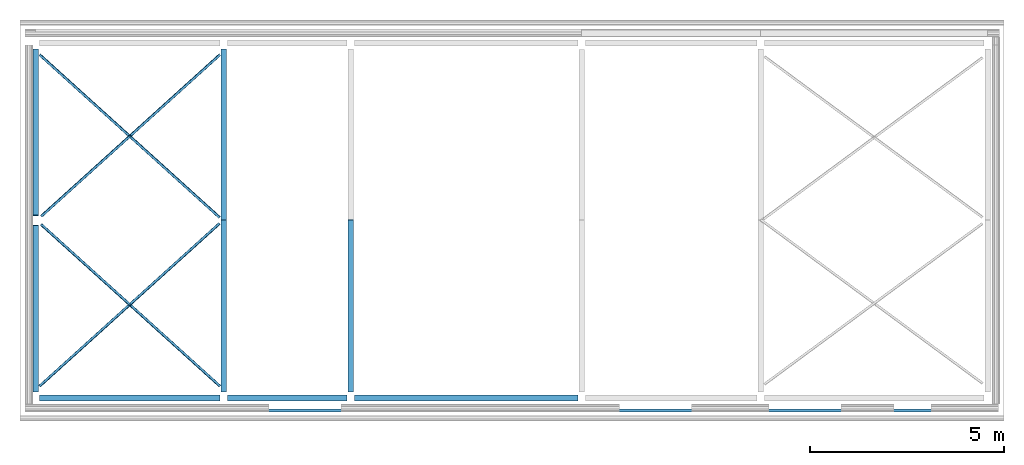
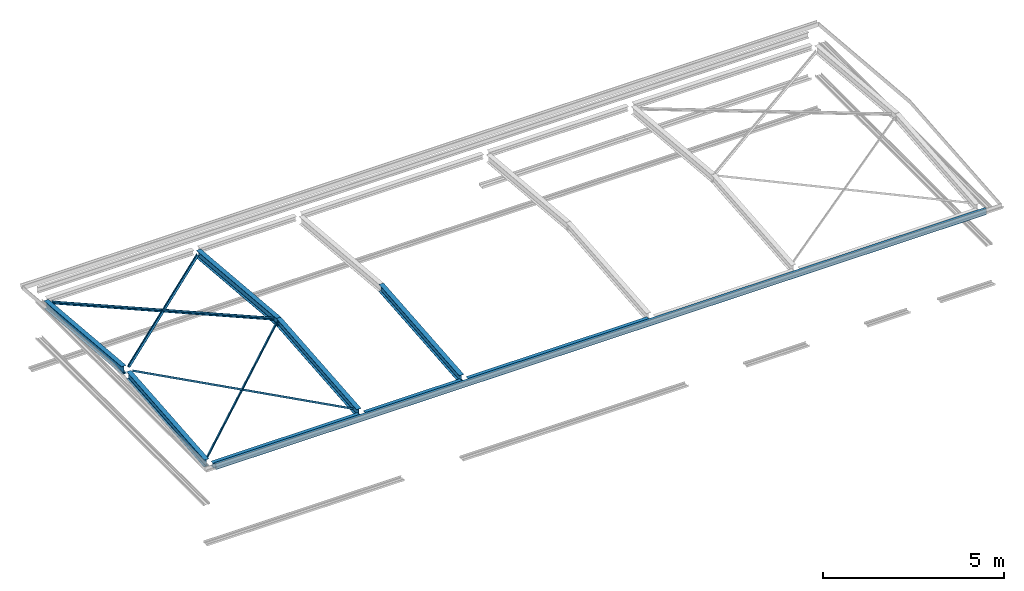
# One storey, part 1 of 8: 13 beams.
"""IFC2X3 building model written with IfcOpenShell, lengths in millimetres."""

from ifc_helpers import new_model, entity, si_unit, converted_unit, money_unit, point, direction, frame, frame_2d, origin_with_axes, place, context, subcontext, project, spatial, polyline, circle_curve, parameter, trimmed, segment, composite_curve, outline, extrude, clip, halfspace, material, type_object, element, save


model = new_model("IFC2X3")

# Units and contexts
model_context = context("Model", 3, precision=1e-05, world=origin_with_axes(), true_north=direction((0.0, 1.0)))
body_context = subcontext(model_context, "Body", "Model", "MODEL_VIEW")
ifc_project = project(units=[si_unit("LENGTHUNIT", "METRE", prefix="MILLI"), si_unit("AREAUNIT", "SQUARE_METRE"), si_unit("VOLUMEUNIT", "CUBIC_METRE"), converted_unit("PLANEANGLEUNIT", "DEGREE", entity("IfcPlaneAngleMeasure", 0.0174532925199), si_unit("PLANEANGLEUNIT", "RADIAN"), dimensions=[0, 0, 0, 0, 0, 0, 0]), si_unit("SOLIDANGLEUNIT", "STERADIAN"), money_unit("USD"), converted_unit("TIMEUNIT", "Year", entity("IfcTimeMeasure", 31556926.0), si_unit("TIMEUNIT", "SECOND"), dimensions=[0, 0, 0, 0, 0, 0, 0]), si_unit("MASSUNIT", "GRAM"), si_unit("THERMODYNAMICTEMPERATUREUNIT", "DEGREE_CELSIUS"), si_unit("LUMINOUSINTENSITYUNIT", "LUMEN")], contexts=[model_context])

# Site, building, storey
site_placement = place(None, origin_with_axes())
site = spatial("IfcSite", under=ifc_project, at=site_placement, CompositionType="ELEMENT")
building_placement = place(site_placement, origin_with_axes())
building = spatial("IfcBuilding", under=site, at=building_placement, CompositionType="ELEMENT")
storey_placement = place(building_placement, frame((0.0, 0.0, 74215.0), z_axis=(0.0, 0.0, 1.0), x_axis=(1.0, 0.0, 0.0)))
storey = spatial("IfcBuildingStorey", under=building, at=storey_placement, CompositionType="ELEMENT", Elevation=74215.0)

# Beams
ifc_material = material(Name="Metal - Steel 43-275")
beam_type_1 = type_object("IfcBeamType", Name="UB254x146x31 (1) 251 x 146", PredefinedType="NOTDEFINED")
beam_1_placement = place(storey_placement, frame((-3274.22088657, 3613.7891505, 267.014681752), z_axis=(0.0, 0.0, 1.0), x_axis=(-1.0, 0.0, 0.0)))
element("IfcBeam", 1, at=beam_1_placement, inside=storey, type_object=beam_type_1, material=ifc_material, Name="UB-Universal Beams:UB254x146x31", ObjectType="UB-Universal Beams:UB254x146x31", context=body_context, shape_type="Clipping", body=[
    clip(clip(clip(clip(extrude(outline(composite_curve([segment(polyline([(125.7, 73.05), (117.1, 73.05), (117.1, 10.6)]), True, "CONTINUOUS"), segment(trimmed(circle_curve(frame_2d((109.5, 10.6), x_axis=(0.0, -1.0)), 7.6), [point((117.1, 10.6)), parameter(90.0)], [point((109.5, 3.0)), parameter(0.0)], False, "CARTESIAN"), True, "CONTINUOUS"), segment(polyline([(109.5, 3.0), (-109.5, 3.0)]), True, "CONTINUOUS"), segment(trimmed(circle_curve(frame_2d((-109.5, 10.6), x_axis=(-1.0, 0.0)), 7.6), [point((-109.5, 3.0)), parameter(90.0)], [point((-117.1, 10.6)), parameter(0.0)], False, "CARTESIAN"), True, "CONTINUOUS"), segment(polyline([(-117.1, 10.6), (-117.1, 73.05), (-125.7, 73.05), (-125.7, -73.05), (-117.1, -73.05), (-117.1, -10.6)]), True, "CONTINUOUS"), segment(trimmed(circle_curve(frame_2d((-109.5, -10.6), x_axis=(0.0, 1.0)), 7.6), [point((-117.1, -10.6)), parameter(90.0)], [point((-109.5, -3.0)), parameter(0.0)], False, "CARTESIAN"), True, "CONTINUOUS"), segment(polyline([(-109.5, -3.0), (109.5, -3.0)]), True, "CONTINUOUS"), segment(trimmed(circle_curve(frame_2d((109.5, -10.6), x_axis=(1.0, 0.0)), 7.6), [point((109.5, -3.0)), parameter(90.0)], [point((117.1, -10.6)), parameter(0.0)], False, "CARTESIAN"), True, "CONTINUOUS"), segment(polyline([(117.1, -10.6), (117.1, -73.05), (125.7, -73.05), (125.7, 73.05)]), True, "CONTINUOUS")], self_intersect=False)), frame((0.0, 4482.93411635, -395.427760455), z_axis=(0.0, -0.996132286365, 0.08786619408), x_axis=(0.0, -0.08786619408, -0.996132286365)), (0.0, 0.0, 1.0), 4518.56524717), halfspace(frame((0.0, 4446.62488753, -392.225019424), z_axis=(0.0, -0.996132286365, 0.08786619408), x_axis=(0.0, -0.08786619408, -0.996132286365)), True)), halfspace(frame((0.0, 18.1546144043, -1.60137051527), z_axis=(0.0, 0.996132286365, -0.08786619408), x_axis=(0.0, 0.08786619408, 0.996132286365)), True)), halfspace(frame((0.0, 4464.77950194, 0.0), z_axis=(0.0, -1.0, 0.0), x_axis=(0.0, 0.0, -1.0)), True)), halfspace(frame((0.0, 0.0, 0.0), z_axis=(0.0, 1.0, 0.0), x_axis=(0.0, 0.0, 1.0)), True)),
])
beam_2_placement = place(storey_placement, frame((-8119.87046131, 3470.08229394, 254.338680059), z_axis=(0.0, 0.0, 1.0), x_axis=(-1.0, 0.0, 0.0)))
element("IfcBeam", 2, at=beam_2_placement, inside=storey, type_object=beam_type_1, material=ifc_material, Name="UB-Universal Beams:UB254x146x31", ObjectType="UB-Universal Beams:UB254x146x31", context=body_context, shape_type="Clipping", body=[
    clip(clip(clip(clip(extrude(outline(composite_curve([segment(polyline([(125.7, 73.05), (117.1, 73.05), (117.1, 10.6)]), True, "CONTINUOUS"), segment(trimmed(circle_curve(frame_2d((109.5, 10.6), x_axis=(0.0, -1.0)), 7.6), [point((117.1, 10.6)), parameter(90.0)], [point((109.5, 3.0)), parameter(0.0)], False, "CARTESIAN"), True, "CONTINUOUS"), segment(polyline([(109.5, 3.0), (-109.5, 3.0)]), True, "CONTINUOUS"), segment(trimmed(circle_curve(frame_2d((-109.5, 10.6), x_axis=(-1.0, 0.0)), 7.6), [point((-109.5, 3.0)), parameter(90.0)], [point((-117.1, 10.6)), parameter(0.0)], False, "CARTESIAN"), True, "CONTINUOUS"), segment(polyline([(-117.1, 10.6), (-117.1, 73.05), (-125.7, 73.05), (-125.7, -73.05), (-117.1, -73.05), (-117.1, -10.6)]), True, "CONTINUOUS"), segment(trimmed(circle_curve(frame_2d((-109.5, -10.6), x_axis=(0.0, 1.0)), 7.6), [point((-117.1, -10.6)), parameter(90.0)], [point((-109.5, -3.0)), parameter(0.0)], False, "CARTESIAN"), True, "CONTINUOUS"), segment(polyline([(-109.5, -3.0), (109.5, -3.0)]), True, "CONTINUOUS"), segment(trimmed(circle_curve(frame_2d((109.5, -10.6), x_axis=(1.0, 0.0)), 7.6), [point((109.5, -3.0)), parameter(90.0)], [point((117.1, -10.6)), parameter(0.0)], False, "CARTESIAN"), True, "CONTINUOUS"), segment(polyline([(117.1, -10.6), (117.1, -73.05), (125.7, -73.05), (125.7, 73.05)]), True, "CONTINUOUS")], self_intersect=False)), frame((0.0, 4339.22725978, -382.751758762), z_axis=(0.0, -0.996132286365, 0.08786619408), x_axis=(0.0, -0.08786619408, -0.996132286365)), (0.0, 0.0, 1.0), 4374.30041555), halfspace(frame((0.0, 4302.91803097, -379.549017731), z_axis=(0.0, -0.996132286365, 0.08786619408), x_axis=(0.0, -0.08786619408, -0.996132286365)), True)), halfspace(frame((0.0, 18.1546144043, -1.60137051527), z_axis=(0.0, 0.996132286365, -0.08786619408), x_axis=(0.0, 0.08786619408, 0.996132286365)), True)), halfspace(frame((0.0, 4321.07264538, 0.0), z_axis=(0.0, -1.0, 0.0), x_axis=(0.0, 0.0, -1.0)), True)), halfspace(frame((0.0, 0.0, 0.0), z_axis=(0.0, 1.0, 0.0), x_axis=(0.0, 0.0, 1.0)), True)),
])
beam_3_placement = place(storey_placement, frame((-8119.87046131, 3684.87754945, 254.338680059), z_axis=(0.0, 0.0, 1.0), x_axis=(1.0, 0.0, 0.0)))
element("IfcBeam", 3, at=beam_3_placement, inside=storey, type_object=beam_type_1, material=ifc_material, Name="UB-Universal Beams:UB254x146x31", ObjectType="UB-Universal Beams:UB254x146x31", context=body_context, shape_type="Clipping", body=[
    clip(clip(clip(clip(extrude(outline(composite_curve([segment(polyline([(125.7, 73.05), (117.1, 73.05), (117.1, 10.6)]), True, "CONTINUOUS"), segment(trimmed(circle_curve(frame_2d((109.5, 10.6), x_axis=(0.0, -1.0)), 7.6), [point((117.1, 10.6)), parameter(90.0)], [point((109.5, 3.0)), parameter(0.0)], False, "CARTESIAN"), True, "CONTINUOUS"), segment(polyline([(109.5, 3.0), (-109.5, 3.0)]), True, "CONTINUOUS"), segment(trimmed(circle_curve(frame_2d((-109.5, 10.6), x_axis=(-1.0, 0.0)), 7.6), [point((-109.5, 3.0)), parameter(90.0)], [point((-117.1, 10.6)), parameter(0.0)], False, "CARTESIAN"), True, "CONTINUOUS"), segment(polyline([(-117.1, 10.6), (-117.1, 73.05), (-125.7, 73.05), (-125.7, -73.05), (-117.1, -73.05), (-117.1, -10.6)]), True, "CONTINUOUS"), segment(trimmed(circle_curve(frame_2d((-109.5, -10.6), x_axis=(0.0, 1.0)), 7.6), [point((-117.1, -10.6)), parameter(90.0)], [point((-109.5, -3.0)), parameter(0.0)], False, "CARTESIAN"), True, "CONTINUOUS"), segment(polyline([(-109.5, -3.0), (109.5, -3.0)]), True, "CONTINUOUS"), segment(trimmed(circle_curve(frame_2d((109.5, -10.6), x_axis=(1.0, 0.0)), 7.6), [point((109.5, -3.0)), parameter(90.0)], [point((117.1, -10.6)), parameter(0.0)], False, "CARTESIAN"), True, "CONTINUOUS"), segment(polyline([(117.1, -10.6), (117.1, -73.05), (125.7, -73.05), (125.7, 73.05)]), True, "CONTINUOUS")], self_intersect=False)), frame((0.0, 4339.22725978, -382.751758762), z_axis=(0.0, -0.996132286365, 0.08786619408), x_axis=(0.0, -0.08786619408, -0.996132286365)), (0.0, 0.0, 1.0), 4374.30041555), halfspace(frame((0.0, 4302.91803097, -379.549017731), z_axis=(0.0, -0.996132286365, 0.08786619408), x_axis=(0.0, -0.08786619408, -0.996132286365)), True)), halfspace(frame((0.0, 18.1546144043, -1.60137051527), z_axis=(0.0, 0.996132286365, -0.08786619408), x_axis=(0.0, 0.08786619408, 0.996132286365)), True)), halfspace(frame((0.0, 4321.07264538, 0.0), z_axis=(0.0, -1.0, 0.0), x_axis=(0.0, 0.0, -1.0)), True)), halfspace(frame((0.0, 0.0, 0.0), z_axis=(0.0, 1.0, 0.0), x_axis=(0.0, 0.0, 1.0)), True)),
])
beam_4_placement = place(storey_placement, frame((-3274.22088657, 3541.17069288, 267.014681752), z_axis=(0.0, 0.0, 1.0), x_axis=(1.0, 0.0, 0.0)))
element("IfcBeam", 4, at=beam_4_placement, inside=storey, type_object=beam_type_1, material=ifc_material, Name="UB-Universal Beams:UB254x146x31", ObjectType="UB-Universal Beams:UB254x146x31", context=body_context, shape_type="Clipping", body=[
    clip(clip(clip(clip(extrude(outline(composite_curve([segment(polyline([(125.7, 73.05), (117.1, 73.05), (117.1, 10.6)]), True, "CONTINUOUS"), segment(trimmed(circle_curve(frame_2d((109.5, 10.6), x_axis=(0.0, -1.0)), 7.6), [point((117.1, 10.6)), parameter(90.0)], [point((109.5, 3.0)), parameter(0.0)], False, "CARTESIAN"), True, "CONTINUOUS"), segment(polyline([(109.5, 3.0), (-109.5, 3.0)]), True, "CONTINUOUS"), segment(trimmed(circle_curve(frame_2d((-109.5, 10.6), x_axis=(-1.0, 0.0)), 7.6), [point((-109.5, 3.0)), parameter(90.0)], [point((-117.1, 10.6)), parameter(0.0)], False, "CARTESIAN"), True, "CONTINUOUS"), segment(polyline([(-117.1, 10.6), (-117.1, 73.05), (-125.7, 73.05), (-125.7, -73.05), (-117.1, -73.05), (-117.1, -10.6)]), True, "CONTINUOUS"), segment(trimmed(circle_curve(frame_2d((-109.5, -10.6), x_axis=(0.0, 1.0)), 7.6), [point((-117.1, -10.6)), parameter(90.0)], [point((-109.5, -3.0)), parameter(0.0)], False, "CARTESIAN"), True, "CONTINUOUS"), segment(polyline([(-109.5, -3.0), (109.5, -3.0)]), True, "CONTINUOUS"), segment(trimmed(circle_curve(frame_2d((109.5, -10.6), x_axis=(1.0, 0.0)), 7.6), [point((109.5, -3.0)), parameter(90.0)], [point((117.1, -10.6)), parameter(0.0)], False, "CARTESIAN"), True, "CONTINUOUS"), segment(polyline([(117.1, -10.6), (117.1, -73.05), (125.7, -73.05), (125.7, 73.05)]), True, "CONTINUOUS")], self_intersect=False)), frame((0.0, 4482.93411635, -395.427760455), z_axis=(0.0, -0.996132286365, 0.08786619408), x_axis=(0.0, -0.08786619408, -0.996132286365)), (0.0, 0.0, 1.0), 4518.56524717), halfspace(frame((0.0, 4446.62488753, -392.225019424), z_axis=(0.0, -0.996132286365, 0.08786619408), x_axis=(0.0, -0.08786619408, -0.996132286365)), True)), halfspace(frame((0.0, 18.1546144043, -1.60137051527), z_axis=(0.0, 0.996132286365, -0.08786619408), x_axis=(0.0, 0.08786619408, 0.996132286365)), True)), halfspace(frame((0.0, 4464.77950194, 0.0), z_axis=(0.0, -1.0, 0.0), x_axis=(0.0, 0.0, -1.0)), True)), halfspace(frame((0.0, 0.0, 0.0), z_axis=(0.0, 1.0, 0.0), x_axis=(0.0, 0.0, 1.0)), True)),
])
beam_5_placement = place(storey_placement, frame((-6.72084898817, 3613.7891505, 267.014681752), z_axis=(0.0, 0.0, 1.0), x_axis=(-1.0, 0.0, 0.0)))
element("IfcBeam", 5, at=beam_5_placement, inside=storey, type_object=beam_type_1, material=ifc_material, Name="UB-Universal Beams:UB254x146x31", ObjectType="UB-Universal Beams:UB254x146x31", context=body_context, shape_type="Clipping", body=[
    clip(clip(clip(clip(extrude(outline(composite_curve([segment(polyline([(125.7, 73.05), (117.1, 73.05), (117.1, 10.6)]), True, "CONTINUOUS"), segment(trimmed(circle_curve(frame_2d((109.5, 10.6), x_axis=(0.0, -1.0)), 7.6), [point((117.1, 10.6)), parameter(90.0)], [point((109.5, 3.0)), parameter(0.0)], False, "CARTESIAN"), True, "CONTINUOUS"), segment(polyline([(109.5, 3.0), (-109.5, 3.0)]), True, "CONTINUOUS"), segment(trimmed(circle_curve(frame_2d((-109.5, 10.6), x_axis=(-1.0, 0.0)), 7.6), [point((-109.5, 3.0)), parameter(90.0)], [point((-117.1, 10.6)), parameter(0.0)], False, "CARTESIAN"), True, "CONTINUOUS"), segment(polyline([(-117.1, 10.6), (-117.1, 73.05), (-125.7, 73.05), (-125.7, -73.05), (-117.1, -73.05), (-117.1, -10.6)]), True, "CONTINUOUS"), segment(trimmed(circle_curve(frame_2d((-109.5, -10.6), x_axis=(0.0, 1.0)), 7.6), [point((-117.1, -10.6)), parameter(90.0)], [point((-109.5, -3.0)), parameter(0.0)], False, "CARTESIAN"), True, "CONTINUOUS"), segment(polyline([(-109.5, -3.0), (109.5, -3.0)]), True, "CONTINUOUS"), segment(trimmed(circle_curve(frame_2d((109.5, -10.6), x_axis=(1.0, 0.0)), 7.6), [point((109.5, -3.0)), parameter(90.0)], [point((117.1, -10.6)), parameter(0.0)], False, "CARTESIAN"), True, "CONTINUOUS"), segment(polyline([(117.1, -10.6), (117.1, -73.05), (125.7, -73.05), (125.7, 73.05)]), True, "CONTINUOUS")], self_intersect=False)), frame((0.0, 4482.93411635, -395.427760455), z_axis=(0.0, -0.996132286365, 0.08786619408), x_axis=(0.0, -0.08786619408, -0.996132286365)), (0.0, 0.0, 1.0), 4518.56524717), halfspace(frame((0.0, 4446.62488753, -392.225019424), z_axis=(0.0, -0.996132286365, 0.08786619408), x_axis=(0.0, -0.08786619408, -0.996132286365)), True)), halfspace(frame((0.0, 18.1546144043, -1.60137051527), z_axis=(0.0, 0.996132286365, -0.08786619408), x_axis=(0.0, 0.08786619408, 0.996132286365)), True)), halfspace(frame((0.0, 4464.77950194, 0.0), z_axis=(0.0, -1.0, 0.0), x_axis=(0.0, 0.0, -1.0)), True)), halfspace(frame((0.0, 0.0, 0.0), z_axis=(0.0, 1.0, 0.0), x_axis=(0.0, 0.0, 1.0)), True)),
])
beam_type_2 = type_object("IfcBeamType", Name="UC152x152x23 152 x 152", PredefinedType="NOTDEFINED")
beam_6_placement = place(storey_placement, frame((-3369.44567394, -995.620091701, -116.2), z_axis=(0.0, 0.0, 1.0), x_axis=(0.0, 1.0, 0.0)))
element("IfcBeam", 6, at=beam_6_placement, inside=storey, type_object=beam_type_2, material=ifc_material, Name="UC-Universal Columns:UC152x152x23", ObjectType="UC-Universal Columns:UC152x152x23", context=body_context, shape_type="SweptSolid", body=[
    extrude(outline(composite_curve([segment(polyline([(76.2, 76.1), (69.4, 76.1), (69.4, 10.4999999999)]), True, "CONTINUOUS"), segment(trimmed(circle_curve(frame_2d((61.8, 10.4999999999), x_axis=(0.0, -1.0)), 7.60000000002), [point((69.4, 10.4999999999)), parameter(90.0)], [point((61.8, 2.89999999987)), parameter(0.0)], False, "CARTESIAN"), True, "CONTINUOUS"), segment(polyline([(61.8, 2.89999999987), (-61.8, 2.89999999987)]), True, "CONTINUOUS"), segment(trimmed(circle_curve(frame_2d((-61.8, 10.4999999999), x_axis=(-1.0, 0.0)), 7.60000000002), [point((-61.8, 2.89999999987)), parameter(90.0)], [point((-69.4, 10.4999999999)), parameter(0.0)], False, "CARTESIAN"), True, "CONTINUOUS"), segment(polyline([(-69.4, 10.4999999999), (-69.4, 76.1), (-76.2, 76.1), (-76.2, -76.1), (-69.4, -76.1), (-69.4, -10.4999999999)]), True, "CONTINUOUS"), segment(trimmed(circle_curve(frame_2d((-61.8, -10.4999999999), x_axis=(0.0, 1.0)), 7.60000000002), [point((-69.4, -10.4999999999)), parameter(90.0)], [point((-61.8, -2.89999999987)), parameter(0.0)], False, "CARTESIAN"), True, "CONTINUOUS"), segment(polyline([(-61.8, -2.89999999987), (61.8, -2.89999999987)]), True, "CONTINUOUS"), segment(trimmed(circle_curve(frame_2d((61.8, -10.4999999999), x_axis=(1.0, 0.0)), 7.60000000002), [point((61.8, -2.89999999987)), parameter(90.0)], [point((69.4, -10.4999999999)), parameter(0.0)], False, "CARTESIAN"), True, "CONTINUOUS"), segment(polyline([(69.4, -10.4999999999), (69.4, -76.1), (76.2, -76.1), (76.2, 76.1)]), True, "CONTINUOUS")], self_intersect=False)), frame((0.0, 4655.2, 0.0), z_axis=(0.0, -1.0, 0.0), x_axis=(0.0, 0.0, -1.0)), (0.0, 0.0, 1.0), 4655.2),
])
beam_7_placement = place(storey_placement, frame((-101.92086778, -995.620091701, -116.2), z_axis=(0.0, 0.0, 1.0), x_axis=(0.0, 1.0, 0.0)))
element("IfcBeam", 7, at=beam_7_placement, inside=storey, type_object=beam_type_2, material=ifc_material, Name="UC-Universal Columns:UC152x152x23", ObjectType="UC-Universal Columns:UC152x152x23", context=body_context, shape_type="SweptSolid", body=[
    extrude(outline(composite_curve([segment(polyline([(76.2, 76.1), (69.4, 76.1), (69.4, 10.4999999999)]), True, "CONTINUOUS"), segment(trimmed(circle_curve(frame_2d((61.8, 10.4999999999), x_axis=(0.0, -1.0)), 7.60000000002), [point((69.4, 10.4999999999)), parameter(90.0)], [point((61.8, 2.89999999987)), parameter(0.0)], False, "CARTESIAN"), True, "CONTINUOUS"), segment(polyline([(61.8, 2.89999999987), (-61.8, 2.89999999987)]), True, "CONTINUOUS"), segment(trimmed(circle_curve(frame_2d((-61.8, 10.4999999999), x_axis=(-1.0, 0.0)), 7.60000000002), [point((-61.8, 2.89999999987)), parameter(90.0)], [point((-69.4, 10.4999999999)), parameter(0.0)], False, "CARTESIAN"), True, "CONTINUOUS"), segment(polyline([(-69.4, 10.4999999999), (-69.4, 76.1), (-76.2, 76.1), (-76.2, -76.1), (-69.4, -76.1), (-69.4, -10.4999999999)]), True, "CONTINUOUS"), segment(trimmed(circle_curve(frame_2d((-61.8, -10.4999999999), x_axis=(0.0, 1.0)), 7.60000000002), [point((-69.4, -10.4999999999)), parameter(90.0)], [point((-61.8, -2.89999999987)), parameter(0.0)], False, "CARTESIAN"), True, "CONTINUOUS"), segment(polyline([(-61.8, -2.89999999987), (61.8, -2.89999999987)]), True, "CONTINUOUS"), segment(trimmed(circle_curve(frame_2d((61.8, -10.4999999999), x_axis=(1.0, 0.0)), 7.60000000002), [point((61.8, -2.89999999987)), parameter(90.0)], [point((69.4, -10.4999999999)), parameter(0.0)], False, "CARTESIAN"), True, "CONTINUOUS"), segment(polyline([(69.4, -10.4999999999), (69.4, -76.1), (76.2, -76.1), (76.2, 76.1)]), True, "CONTINUOUS")], self_intersect=False)), frame((0.0, 3077.1, 0.0), z_axis=(0.0, -1.0, 0.0), x_axis=(0.0, 0.0, -1.0)), (0.0, 0.0, 1.0), 3077.1),
])
beam_8_placement = place(storey_placement, frame((5850.9874698, -995.620091702, -116.2), z_axis=(0.0, 0.0, 1.0), x_axis=(0.0, 1.0, 0.0)))
element("IfcBeam", 8, at=beam_8_placement, inside=storey, type_object=beam_type_2, material=ifc_material, Name="UC-Universal Columns:UC152x152x23", ObjectType="UC-Universal Columns:UC152x152x23", context=body_context, shape_type="SweptSolid", body=[
    extrude(outline(composite_curve([segment(polyline([(76.2, 76.1), (69.4, 76.1), (69.4, 10.4999999999)]), True, "CONTINUOUS"), segment(trimmed(circle_curve(frame_2d((61.8, 10.4999999999), x_axis=(0.0, -1.0)), 7.60000000002), [point((69.4, 10.4999999999)), parameter(90.0)], [point((61.8, 2.89999999987)), parameter(0.0)], False, "CARTESIAN"), True, "CONTINUOUS"), segment(polyline([(61.8, 2.89999999987), (-61.8, 2.89999999987)]), True, "CONTINUOUS"), segment(trimmed(circle_curve(frame_2d((-61.8, 10.4999999999), x_axis=(-1.0, 0.0)), 7.60000000002), [point((-61.8, 2.89999999987)), parameter(90.0)], [point((-69.4, 10.4999999999)), parameter(0.0)], False, "CARTESIAN"), True, "CONTINUOUS"), segment(polyline([(-69.4, 10.4999999999), (-69.4, 76.1), (-76.2, 76.1), (-76.2, -76.1), (-69.4, -76.1), (-69.4, -10.4999999999)]), True, "CONTINUOUS"), segment(trimmed(circle_curve(frame_2d((-61.8, -10.4999999999), x_axis=(0.0, 1.0)), 7.60000000002), [point((-69.4, -10.4999999999)), parameter(90.0)], [point((-61.8, -2.89999999987)), parameter(0.0)], False, "CARTESIAN"), True, "CONTINUOUS"), segment(polyline([(-61.8, -2.89999999987), (61.8, -2.89999999987)]), True, "CONTINUOUS"), segment(trimmed(circle_curve(frame_2d((61.8, -10.4999999999), x_axis=(1.0, 0.0)), 7.60000000002), [point((61.8, -2.89999999987)), parameter(90.0)], [point((69.4, -10.4999999999)), parameter(0.0)], False, "CARTESIAN"), True, "CONTINUOUS"), segment(polyline([(69.4, -10.4999999999), (69.4, -76.1), (76.2, -76.1), (76.2, 76.1)]), True, "CONTINUOUS")], self_intersect=False)), frame((0.0, 5762.5, 0.0), z_axis=(0.0, -1.0, 0.0), x_axis=(0.0, 0.0, -1.0)), (0.0, 0.0, 1.0), 5762.5),
])
beam_type_3 = type_object("IfcBeamType", Name="L70x70x7 70 x 70", PredefinedType="NOTDEFINED")
beam_9_placement = place(storey_placement, frame((-7992.07752569, 3471.00567283, 336.535227844), z_axis=(0.0, 0.0, 1.0), x_axis=(-0.67073896884, -0.741693491734, 0.0)))
element("IfcBeam", 9, at=beam_9_placement, inside=storey, type_object=beam_type_3, material=ifc_material, Name="L-Equal Leg Angles:L70x70x7", ObjectType="L-Equal Leg Angles:L70x70x7", context=body_context, shape_type="Clipping", body=[
    clip(clip(clip(clip(extrude(outline(composite_curve([segment(polyline([(23.9444444444, -43.5555555556), (26.4444444444, -43.5555555556), (26.4444444444, 26.4444444444), (-43.5555555556, 26.4444444445), (-43.5555555556, 23.9444444445)]), True, "CONTINUOUS"), segment(trimmed(circle_curve(frame_2d((-39.0555555556, 23.9444444445), x_axis=(-1.0, 0.0)), 4.5), [point((-43.5555555556, 23.9444444445)), parameter(0.0)], [point((-39.0555555555, 19.4444444445)), parameter(90.0000000013)], True, "CARTESIAN"), True, "CONTINUOUS"), segment(polyline([(-39.0555555555, 19.4444444445), (10.4444444444, 19.4444444444)]), True, "CONTINUOUS"), segment(trimmed(circle_curve(frame_2d((10.4444444444, 10.4444444444), x_axis=(1.0, 0.0)), 9.0), [point((10.4444444444, 19.4444444444)), parameter(90.0)], [point((19.4444444444, 10.4444444444)), parameter(0.0)], False, "CARTESIAN"), True, "CONTINUOUS"), segment(polyline([(19.4444444444, 10.4444444444), (19.4444444444, -39.0555555556)]), True, "CONTINUOUS"), segment(trimmed(circle_curve(frame_2d((23.9444444444, -39.0555555556), x_axis=(-1.0, 0.0)), 4.5), [point((19.4444444444, -39.0555555556)), parameter(0.0)], [point((23.9444444444, -43.5555555556)), parameter(90.0)], True, "CARTESIAN"), True, "CONTINUOUS")], self_intersect=False)), frame((0.0, 6232.07302353, -368.715055444), z_axis=(0.0, -0.998254385446, 0.0590608325171), x_axis=(0.0, -0.0590608325171, -0.998254385446)), (0.0, 0.0, 1.0), 6248.8277924), halfspace(frame((0.0, 6220.37957528, -368.023222983), z_axis=(0.0, -0.998254385446, 0.0590608325171), x_axis=(0.0, -0.0590608325171, -0.998254385446)), True)), halfspace(frame((0.0, 5.84672412455, -0.345916230701), z_axis=(0.0, 0.998254385446, -0.0590608325171), x_axis=(0.0, 0.0590608325171, 0.998254385446)), True)), halfspace(frame((0.0, 6226.22629941, 0.0), z_axis=(0.0, -1.0, 0.0), x_axis=(0.0, 0.0, -1.0)), True)), halfspace(frame((0.0, 0.0, 0.0), z_axis=(0.0, 1.0, 0.0), x_axis=(0.0, 0.0, 1.0)), True)),
])
beam_10_placement = place(storey_placement, frame((-3371.25025285, 3656.13361529, 338.989205435), z_axis=(0.0, 0.0, 1.0), x_axis=(0.67073896884, 0.741693491734, 0.0)))
element("IfcBeam", 10, at=beam_10_placement, inside=storey, type_object=beam_type_3, material=ifc_material, Name="L-Equal Leg Angles:L70x70x7", ObjectType="L-Equal Leg Angles:L70x70x7", context=body_context, shape_type="Clipping", body=[
    clip(clip(clip(clip(extrude(outline(composite_curve([segment(polyline([(23.9444444444, -43.5555555556), (26.4444444444, -43.5555555556), (26.4444444444, 26.4444444444), (-43.5555555556, 26.4444444445), (-43.5555555556, 23.9444444445)]), True, "CONTINUOUS"), segment(trimmed(circle_curve(frame_2d((-39.0555555556, 23.9444444445), x_axis=(-1.0, 0.0)), 4.5), [point((-43.5555555556, 23.9444444445)), parameter(0.0)], [point((-39.0555555555, 19.4444444445)), parameter(90.0000000013)], True, "CARTESIAN"), True, "CONTINUOUS"), segment(polyline([(-39.0555555555, 19.4444444445), (10.4444444444, 19.4444444444)]), True, "CONTINUOUS"), segment(trimmed(circle_curve(frame_2d((10.4444444444, 10.4444444444), x_axis=(1.0, 0.0)), 9.0), [point((10.4444444444, 19.4444444444)), parameter(90.0)], [point((19.4444444444, 10.4444444444)), parameter(0.0)], False, "CARTESIAN"), True, "CONTINUOUS"), segment(polyline([(19.4444444444, 10.4444444444), (19.4444444444, -39.0555555556)]), True, "CONTINUOUS"), segment(trimmed(circle_curve(frame_2d((23.9444444444, -39.0555555556), x_axis=(-1.0, 0.0)), 4.5), [point((19.4444444444, -39.0555555556)), parameter(0.0)], [point((23.9444444444, -43.5555555556)), parameter(90.0)], True, "CARTESIAN"), True, "CONTINUOUS")], self_intersect=False)), frame((0.0, 6273.60040596, -371.171986077), z_axis=(0.0, -0.998254385446, 0.0590608325171), x_axis=(0.0, -0.0590608325171, -0.998254385446)), (0.0, 0.0, 1.0), 6290.42779239), halfspace(frame((0.0, 6261.90695772, -370.480153616), z_axis=(0.0, -0.998254385446, 0.0590608325171), x_axis=(0.0, -0.0590608325171, -0.998254385446)), True)), halfspace(frame((0.0, 5.84672412452, -0.345916230699), z_axis=(0.0, 0.998254385446, -0.0590608325171), x_axis=(0.0, 0.0590608325171, 0.998254385446)), True)), halfspace(frame((0.0, 6267.75368184, 0.0), z_axis=(0.0, -1.0, 0.0), x_axis=(0.0, 0.0, -1.0)), True)), halfspace(frame((0.0, 0.0, 0.0), z_axis=(0.0, 1.0, 0.0), x_axis=(0.0, 0.0, 1.0)), True)),
])
beam_type_4 = type_object("IfcBeamType", Name="L70x70x7 (1) 70 x 70", PredefinedType="NOTDEFINED")
beam_11_placement = place(storey_placement, frame((-3371.25025285, 3498.8262281, 338.989205435), z_axis=(0.0, 0.0, 1.0), x_axis=(-0.67073896884, 0.741693491734, 0.0)))
element("IfcBeam", 11, at=beam_11_placement, inside=storey, type_object=beam_type_4, material=ifc_material, Name="L-Equal Leg Angles:L70x70x7", ObjectType="L-Equal Leg Angles:L70x70x7", context=body_context, shape_type="Clipping", body=[
    clip(clip(clip(clip(extrude(outline(composite_curve([segment(polyline([(-43.5555555556, -26.4444444444), (26.4444444444, -26.4444444444), (26.4444444444, 43.5555555556), (23.9444444444, 43.5555555556)]), True, "CONTINUOUS"), segment(trimmed(circle_curve(frame_2d((23.9444444444, 39.0555555556), x_axis=(0.0, 1.0)), 4.5), [point((23.9444444444, 43.5555555556)), parameter(0.0)], [point((19.4444444444, 39.0555555555)), parameter(90.0000000013)], True, "CARTESIAN"), True, "CONTINUOUS"), segment(polyline([(19.4444444444, 39.0555555555), (19.4444444444, -10.4444444444)]), True, "CONTINUOUS"), segment(trimmed(circle_curve(frame_2d((10.4444444444, -10.4444444444), x_axis=(0.0, -1.0)), 9.0), [point((19.4444444444, -10.4444444444)), parameter(90.0)], [point((10.4444444444, -19.4444444444)), parameter(0.0)], False, "CARTESIAN"), True, "CONTINUOUS"), segment(polyline([(10.4444444444, -19.4444444444), (-39.0555555556, -19.4444444444)]), True, "CONTINUOUS"), segment(trimmed(circle_curve(frame_2d((-39.0555555556, -23.9444444443), x_axis=(0.0, 1.0)), 4.49999999995), [point((-39.0555555556, -19.4444444444)), parameter(0.0)], [point((-43.5555555555, -23.9444444445)), parameter(90.0000000013)], True, "CARTESIAN"), True, "CONTINUOUS"), segment(polyline([(-43.5555555555, -23.9444444445), (-43.5555555556, -26.4444444444)]), True, "CONTINUOUS")], self_intersect=False)), frame((0.0, 6273.60040596, -371.171986077), z_axis=(0.0, -0.998254385446, 0.0590608325171), x_axis=(0.0, -0.0590608325171, -0.998254385446)), (0.0, 0.0, 1.0), 6290.42779239), halfspace(frame((0.0, 6261.90695772, -370.480153616), z_axis=(0.0, -0.998254385446, 0.0590608325171), x_axis=(0.0, -0.0590608325171, -0.998254385446)), True)), halfspace(frame((0.0, 5.84672412452, -0.345916230699), z_axis=(0.0, 0.998254385446, -0.0590608325171), x_axis=(0.0, 0.0590608325171, 0.998254385446)), True)), halfspace(frame((0.0, 6267.75368184, 0.0), z_axis=(0.0, -1.0, 0.0), x_axis=(0.0, 0.0, -1.0)), True)), halfspace(frame((0.0, 0.0, 0.0), z_axis=(0.0, 1.0, 0.0), x_axis=(0.0, 0.0, 1.0)), True)),
])
beam_12_placement = place(storey_placement, frame((-7992.07752569, 3683.95417056, 336.535227844), z_axis=(0.0, 0.0, 1.0), x_axis=(0.67073896884, -0.741693491734, 0.0)))
element("IfcBeam", 12, at=beam_12_placement, inside=storey, type_object=beam_type_4, material=ifc_material, Name="L-Equal Leg Angles:L70x70x7", ObjectType="L-Equal Leg Angles:L70x70x7", context=body_context, shape_type="Clipping", body=[
    clip(clip(clip(clip(extrude(outline(composite_curve([segment(polyline([(-43.5555555556, -26.4444444444), (26.4444444444, -26.4444444444), (26.4444444444, 43.5555555556), (23.9444444444, 43.5555555556)]), True, "CONTINUOUS"), segment(trimmed(circle_curve(frame_2d((23.9444444444, 39.0555555556), x_axis=(0.0, 1.0)), 4.5), [point((23.9444444444, 43.5555555556)), parameter(0.0)], [point((19.4444444444, 39.0555555555)), parameter(90.0000000013)], True, "CARTESIAN"), True, "CONTINUOUS"), segment(polyline([(19.4444444444, 39.0555555555), (19.4444444444, -10.4444444444)]), True, "CONTINUOUS"), segment(trimmed(circle_curve(frame_2d((10.4444444444, -10.4444444444), x_axis=(0.0, -1.0)), 9.0), [point((19.4444444444, -10.4444444444)), parameter(90.0)], [point((10.4444444444, -19.4444444444)), parameter(0.0)], False, "CARTESIAN"), True, "CONTINUOUS"), segment(polyline([(10.4444444444, -19.4444444444), (-39.0555555556, -19.4444444444)]), True, "CONTINUOUS"), segment(trimmed(circle_curve(frame_2d((-39.0555555556, -23.9444444443), x_axis=(0.0, 1.0)), 4.49999999995), [point((-39.0555555556, -19.4444444444)), parameter(0.0)], [point((-43.5555555555, -23.9444444445)), parameter(90.0000000013)], True, "CARTESIAN"), True, "CONTINUOUS"), segment(polyline([(-43.5555555555, -23.9444444445), (-43.5555555556, -26.4444444444)]), True, "CONTINUOUS")], self_intersect=False)), frame((0.0, 6232.07302353, -368.715055444), z_axis=(0.0, -0.998254385446, 0.0590608325171), x_axis=(0.0, -0.0590608325171, -0.998254385446)), (0.0, 0.0, 1.0), 6248.8277924), halfspace(frame((0.0, 6220.37957528, -368.023222983), z_axis=(0.0, -0.998254385446, 0.0590608325171), x_axis=(0.0, -0.0590608325171, -0.998254385446)), True)), halfspace(frame((0.0, 5.84672412456, -0.345916230701), z_axis=(0.0, 0.998254385446, -0.0590608325171), x_axis=(0.0, 0.0590608325171, 0.998254385446)), True)), halfspace(frame((0.0, 6226.22629941, 0.0), z_axis=(0.0, -1.0, 0.0), x_axis=(0.0, 0.0, -1.0)), True)), halfspace(frame((0.0, 0.0, 0.0), z_axis=(0.0, 1.0, 0.0), x_axis=(0.0, 0.0, 1.0)), True)),
])
beam_type_5 = type_object("IfcBeamType", Name="PFC200x75x23 200 x 75", PredefinedType="NOTDEFINED")
beam_13_placement = place(storey_placement, frame((16408.2545075, -1317.52006319, 60.0), z_axis=(0.0, 0.0, 1.0), x_axis=(0.0, 1.0, 0.0)))
element("IfcBeam", 13, at=beam_13_placement, inside=storey, type_object=beam_type_5, material=ifc_material, Name="PFC-Parallel Flange Channels:PFC200x75x23", ObjectType="PFC-Parallel Flange Channels:PFC200x75x23", context=body_context, shape_type="SweptSolid", body=[
    extrude(outline(composite_curve([segment(polyline([(-100.0, -34.8), (100.0, -34.8), (100.0, 40.2), (87.5, 40.2), (87.5, -16.8)]), True, "CONTINUOUS"), segment(trimmed(circle_curve(frame_2d((75.5, -16.8), x_axis=(0.0, -1.0)), 12.0), [point((87.5, -16.8)), parameter(90.0)], [point((75.5, -28.8)), parameter(0.0)], False, "CARTESIAN"), True, "CONTINUOUS"), segment(polyline([(75.5, -28.8), (-75.5, -28.8)]), True, "CONTINUOUS"), segment(trimmed(circle_curve(frame_2d((-75.5, -16.8), x_axis=(-1.0, 0.0)), 12.0), [point((-75.5, -28.8)), parameter(90.0)], [point((-87.5, -16.8)), parameter(0.0)], False, "CARTESIAN"), True, "CONTINUOUS"), segment(polyline([(-87.5, -16.8), (-87.5, 40.2), (-100.0, 40.2), (-100.0, -34.8)]), True, "CONTINUOUS")], self_intersect=False)), frame((0.0, 24528.1, 0.0), z_axis=(0.0, -1.0, 0.0), x_axis=(0.0, 0.0, -1.0)), (0.0, 0.0, 1.0), 24528.1),
])

save(model, "model.ifc")
